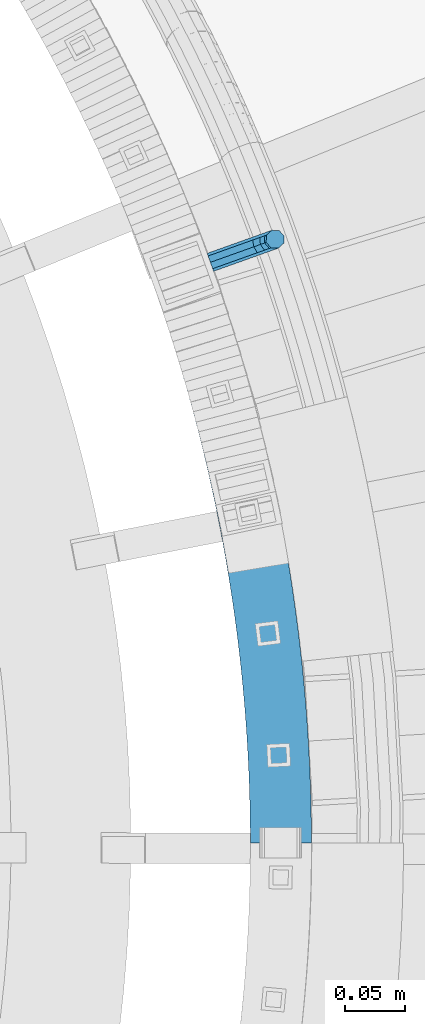
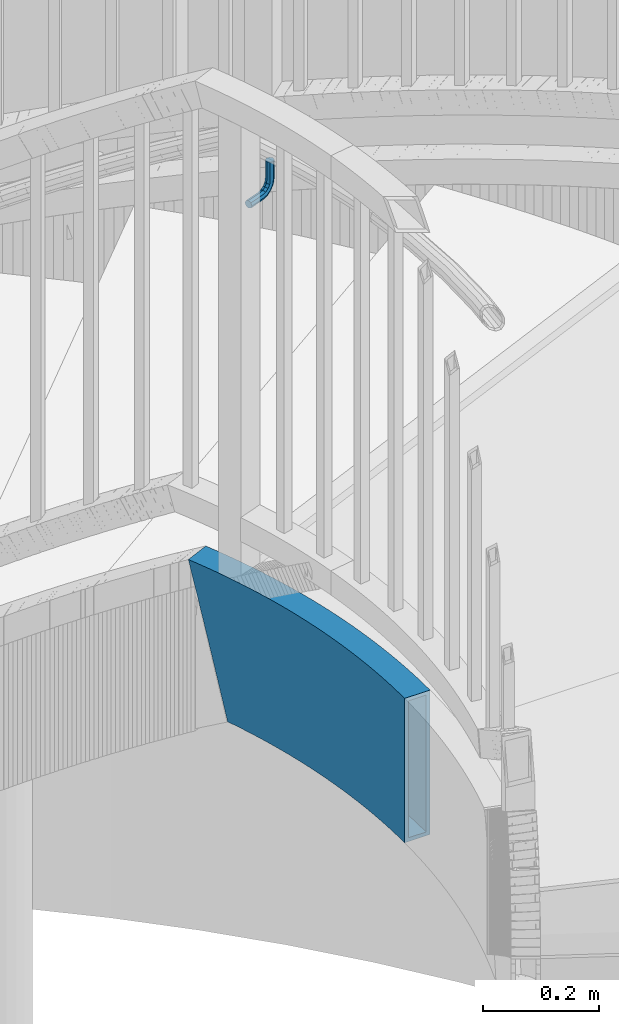
# One storey, part 497 of 975: 2 beams.
"""IFC2X3 building model written with IfcOpenShell, lengths in millimetres."""

from ifc_helpers import new_model, si_unit, frame, origin_with_axes, place, context, subcontext, project, spatial, faceted_brep, material, type_object, element, save


model = new_model("IFC2X3")

# Units and contexts
model_context = context("Model", 3, precision=1e-05, world=origin_with_axes())
body_context = subcontext(model_context, "Body", "Model", "MODEL_VIEW")
ifc_project = project(units=[si_unit("LENGTHUNIT", "METRE", prefix="MILLI"), si_unit("AREAUNIT", "SQUARE_METRE"), si_unit("VOLUMEUNIT", "CUBIC_METRE"), si_unit("MASSUNIT", "GRAM", prefix="KILO"), si_unit("TIMEUNIT", "SECOND"), si_unit("PLANEANGLEUNIT", "RADIAN"), si_unit("SOLIDANGLEUNIT", "STERADIAN"), si_unit("THERMODYNAMICTEMPERATUREUNIT", "DEGREE_CELSIUS"), si_unit("LUMINOUSINTENSITYUNIT", "LUMEN")], contexts=[model_context])

# Site, building, storey
site_placement = place(None, origin_with_axes())
site = spatial("IfcSite", under=ifc_project, at=site_placement, CompositionType="ELEMENT")
building_placement = place(site_placement, origin_with_axes())
building = spatial("IfcBuilding", under=site, at=building_placement, Name="Undefined", CompositionType="ELEMENT")
storey_placement = place(building_placement, origin_with_axes())
storey = spatial("IfcBuildingStorey", under=building, at=storey_placement, Name="Undefined", CompositionType="ELEMENT", Elevation=0.0)

# Beams
ifc_material_1 = material(Name="STEEL/A36")
beam_type_1 = type_object("IfcBeamType", PredefinedType="NOTDEFINED")
beam_1_placement = place(storey_placement, frame((36072.5932851739, 3886.01904978759, 2946.4), z_axis=(0.0, 0.0, 1.0), x_axis=(0.941586681128456, 0.336770726045925, 0.0)))
element("IfcBeam", 1, at=beam_1_placement, inside=storey, type_object=beam_type_1, material=ifc_material_1, Name="BRACKET", context=body_context, shape_type="Brep", body=[
    faceted_brep([(-4.22995071858168e-07, -7.93750000000728, 0.0), (-2.99107341561466e-07, -5.61266007567065, -5.61266007566792), (31.7501749944095, -5.61266176762365, -5.61266007566792), (31.7501748705254, -7.93750169196028, 0.0), (-1.09139364212751e-11, 1.81898940354586e-12, -7.9375), (31.7501752935095, -1.69195118360221e-06, -7.9375), (2.99089151667431e-07, 5.61266007567428, -5.61266007566792), (31.7501755926023, 5.61265838372674, -5.61266007566792), (4.22980519942939e-07, 7.93750000001091, 0.0), (31.75017571649, 7.93749830806155, 0.0), (2.99089151667431e-07, 5.61266007567428, 5.61266007566792), (31.7501755926023, 5.61265838372674, 5.61266007566792), (-1.09139364212751e-11, 1.81898940354586e-12, 7.9375), (31.7501752935095, -1.69195118360221e-06, 7.9375), (-2.99107341561466e-07, -5.61266007567065, 5.61266007566792), (31.7501749944095, -5.61266176762365, 5.61266007566792), (44.5078840739552, -2.37179847317748e-06, -5.39983394413412), (43.6182060529281, -5.61266240006626, -3.2519619216755), (41.4703339065854, -7.93750220993934, 1.93345984517509), (39.3224620080255, -5.61266217115008, 7.11888161202842), (38.4327845851803, -2.0480601961026e-06, 9.26675363448339), (39.3224626062183, 5.61265798020031, 7.11888161202842), (41.4703347525501, 7.93749779008067, 1.93345984517509), (43.6182066511174, 5.61265775128231, -3.25196192167823), (53.6794375649406, 5.61265721512609, 3.47073764613469), (55.3233473415094, -2.94815072265919e-06, 1.82682757046678), (49.7106876888392, 7.93749735095298, 7.43948764613469), (45.7419375649588, 5.61265763811389, 11.4082376461338), (44.0980271902044, -2.34995968639851e-06, 13.0521477218017), (45.7419369667659, -5.6126625132365, 11.4082376461338), (49.7106868428746, -7.93750264906703, 7.43948764613469), (53.6794369667477, -5.6126629362243, 3.47073764613469), (60.402137132729, 5.61265685687795, 13.5319685599879), (62.5500088560802, -3.3332562452415e-06, 12.6422908380455), (55.2167154897834, 7.93749705753908, 15.6798405824429), (50.0312935990514, 5.61265740953786, 17.827712604897), (47.8834212775073, -2.55168015428353e-06, 18.7173903268394), (50.0312930008622, -5.61266274181617, 17.827712604897), (55.2167146438078, -7.93750294247729, 15.6798405824429), (60.4021365345397, -5.61266329447426, 13.5319685599879), (62.7628352867068, 5.61265673108028, 25.3999996185303), (65.0876749119416, -3.46848719345871e-06, 25.3999996185303), (57.1501753349476, 7.9374969545097, 25.3999996185303), (51.5375151354019, 5.6126573292695, 25.3999996185303), (49.2126749119889, -2.62251523963641e-06, 25.3999996185303), (51.5375145372127, -5.61266282207907, 25.3999996185303), (57.1501744889792, -7.93750304551213, 25.3999996185303), (62.762834688514, -5.61266342027193, 25.3999996185303), (62.762834688514, -5.61266342027193, 63.5), (57.1501744889792, -7.93750304551213, 63.5), (65.0876749119416, -3.46848719345871e-06, 63.5), (62.7628352867068, 5.61265673108028, 63.5), (57.1501753349476, 7.9374969545097, 63.5), (51.5375151354019, 5.6126573292695, 63.5), (49.2126749119889, -2.62251523963641e-06, 63.5), (51.5375145372127, -5.61266282207907, 63.5)], [[[0, 1, 2, 3]], [[1, 4, 5, 2]], [[4, 6, 7, 5]], [[6, 8, 9, 7]], [[8, 10, 11, 9]], [[10, 12, 13, 11]], [[12, 14, 15, 13]], [[14, 0, 3, 15]], [[14, 12, 10, 8, 6, 4, 1, 0]], [[2, 5, 16, 17]], [[3, 2, 17, 18]], [[15, 3, 18, 19]], [[13, 15, 19, 20]], [[11, 13, 20, 21]], [[9, 11, 21, 22]], [[7, 9, 22, 23]], [[5, 7, 23, 16]], [[23, 24, 25, 16]], [[22, 26, 24, 23]], [[21, 27, 26, 22]], [[20, 28, 27, 21]], [[19, 29, 28, 20]], [[18, 30, 29, 19]], [[17, 31, 30, 18]], [[16, 25, 31, 17]], [[24, 32, 33, 25]], [[26, 34, 32, 24]], [[27, 35, 34, 26]], [[28, 36, 35, 27]], [[29, 37, 36, 28]], [[30, 38, 37, 29]], [[31, 39, 38, 30]], [[25, 33, 39, 31]], [[32, 40, 41, 33]], [[34, 42, 40, 32]], [[35, 43, 42, 34]], [[36, 44, 43, 35]], [[37, 45, 44, 36]], [[38, 46, 45, 37]], [[39, 47, 46, 38]], [[33, 41, 47, 39]], [[46, 47, 48, 49]], [[47, 41, 50, 48]], [[41, 40, 51, 50]], [[40, 42, 52, 51]], [[42, 43, 53, 52]], [[43, 44, 54, 53]], [[44, 45, 55, 54]], [[45, 46, 49, 55]], [[50, 51, 52, 53, 54, 55, 49, 48]]]),
])
ifc_material_2 = material()
beam_type_2 = type_object("IfcBeamType", Name="HSS12X2X5/16", PredefinedType="NOTDEFINED")
beam_2_placement = place(storey_placement, frame((36020.327060371, 3949.87201722461, 2031.99999923706), z_axis=(0.0, 0.0, 1.0), x_axis=(0.0627814950101885, -0.998027296161926, 0.0)))
element("IfcBeam", 2, at=beam_2_placement, inside=storey, type_object=beam_type_2, material=ifc_material_2, Name="STAIR", ObjectType="HSS12X2X5/16", context=body_context, shape_type="Brep", body=[
    faceted_brep([(519.591668239296, 52.6082079811895, 152.4), (519.591668239296, 52.6082079811895, -152.4), (535.331694518953, 51.8875589797681, -152.4), (535.331694518953, 51.8875589797681, 152.4), (503.84442888955, 53.1487772453038, 152.4), (503.84442888955, 53.1487772453038, -152.4), (488.092036672716, 53.5091960497084, 152.4), (488.092036672716, 53.5091960497084, -152.4), (472.336552465947, 53.6894172410102, 152.4), (472.336552465947, 53.6894172410102, -152.4), (456.580037550917, 53.6894172409666, 152.4), (456.580037550917, 53.6894172409666, -152.4), (440.824553344148, 53.5091960495702, 152.4), (440.824553344148, 53.5091960495702, -152.4), (425.072161127315, 53.1487772450782, 152.4), (425.072161127315, 53.1487772450782, -152.4), (409.324921777569, 52.6082079808766, 152.4), (409.324921777569, 52.6082079808766, -152.4), (393.584895497913, 51.8875589793606, 152.4), (393.584895497913, 51.8875589793606, -152.4), (377.854141547671, 50.9869245226655, 152.4), (377.854141547671, 50.9869245226655, -152.4), (362.134717973071, 49.9064224403191, 152.4), (362.134717973071, 49.9064224403191, -152.4), (346.428681337994, 48.6461940938243, 152.4), (346.428681337994, 48.6461940938243, -152.4), (330.738086454916, 47.2064043582141, 152.4), (330.738086454916, 47.2064043582141, -152.4), (315.064986116073, 45.5872416003986, 152.4), (315.064986116073, 45.5872416003986, -152.4), (299.411430824905, 43.7889176545941, 152.4), (299.411430824905, 43.7889176545941, -152.4), (283.779468527779, 41.8116677945654, 152.4), (283.779468527779, 41.8116677945654, -152.4), (268.171144346064, 39.6557507028847, 152.4), (268.171144346064, 39.6557507028847, -152.4), (252.588500308566, 37.3214484370328, 152.4), (252.588500308566, 37.3214484370328, -152.4), (237.033575084371, 34.8090663925468, 152.4), (237.033575084371, 34.8090663925468, -152.4), (221.508403716129, 32.1189332630238, 152.4), (221.508403716129, 32.1189332630238, -152.4), (206.015017353807, 29.2514009971928, 152.4), (206.015017353807, 29.2514009971928, -152.4), (190.555442988958, 26.2068447527636, 152.4), (190.555442988958, 26.2068447527636, -152.4), (175.131703189529, 22.9856628474154, 152.4), (175.131703189529, 22.9856628474154, -152.4), (159.745815835247, 19.5882767066869, 152.4), (159.745815835247, 19.5882767066869, -152.4), (144.399793853627, 16.015130808817, 152.4), (144.399793853627, 16.015130808817, -152.4), (129.095644956617, 12.2666926265811, 152.4), (129.095644956617, 12.2666926265811, -152.4), (113.835371377932, 8.34345256617235, 152.4), (113.835371377932, 8.34345256617235, -152.4), (98.6209696111009, 4.2459239030286, 152.4), (98.6209696111009, 4.2459239030286, -152.4), (83.4544301482701, -0.0253572853616788, 152.4), (83.4544301482701, -0.0253572853616788, -152.4), (-8.40888177997658, 23.967701333444, 152.4), (-8.40888177997658, 23.967701333444, 99.8834567786589), (-22.4314005769725, 18.9577604688093, 152.4), (7.03809672072066, 29.288134936709, 152.4), (7.03809672072066, 29.288134936709, 42.2716439026144), (22.5449192642914, 34.4315397555038, 152.4), (22.5449192642914, 34.4315397555038, -15.3247692192031), (38.1095571013357, 39.3972428808847, 152.4), (38.1095571013357, 39.3972428808847, -72.8982472784946), (53.7299739185078, 44.1845946525355, 152.4), (53.7299739185078, 44.1845946525355, -130.441257967543), (69.4041261049288, 48.7929687437645, 152.4), (69.4041261049288, 48.7929687437645, -152.4), (59.7152721478251, 45.9443385264167, -152.4), (85.1299630195485, 53.2217622434036, 152.4), (85.1299630195485, 53.2217622434036, -152.4), (100.905427259434, 57.4703957347665, 152.4), (100.905427259434, 57.4703957347665, -152.4), (116.72845492893, 61.5383133713476, 152.4), (116.72845492893, 61.5383133713476, -152.4), (132.596975909688, 65.4249829496475, 152.4), (132.596975909688, 65.4249829496475, -152.4), (148.508914131493, 69.1298959787455, 152.4), (148.508914131493, 69.1298959787455, -152.4), (164.462187843872, 72.6525677468162, 152.4), (164.462187843872, 72.6525677468162, -152.4), (180.454709888456, 75.9925373845763, 152.4), (180.454709888456, 75.9925373845763, -152.4), (196.484387972033, 79.1493679255727, 152.4), (196.484387972033, 79.1493679255727, -152.4), (212.54912494029, 82.1226463632993, 152.4), (212.54912494029, 82.1226463632993, -152.4), (228.646819052175, 84.9119837053586, 152.4), (228.646819052175, 84.9119837053586, -152.4), (244.775364254875, 87.5170150241902, 152.4), (244.775364254875, 87.5170150241902, -152.4), (260.93265045934, 89.9373995049173, 152.4), (260.93265045934, 89.9373995049173, -152.4), (277.116563816353, 92.1728204899337, 152.4), (277.116563816353, 92.1728204899337, -152.4), (293.32498699308, 94.2229855202822, 152.4), (293.32498699308, 94.2229855202822, -152.4), (309.55579945008, 96.0876263739628, 152.4), (309.55579945008, 96.0876263739628, -152.4), (325.806877718734, 97.7664991010024, 152.4), (325.806877718734, 97.7664991010024, -152.4), (342.076095679059, 99.2593840553527, 152.4), (342.076095679059, 99.2593840553527, -152.4), (358.361324837864, 100.566085923674, 152.4), (358.361324837864, 100.566085923674, -152.4), (374.660434607222, 101.686433750845, 152.4), (374.660434607222, 101.686433750845, -152.4), (390.971292583215, 102.620280962365, 152.4), (390.971292583215, 102.620280962365, -152.4), (407.291764824909, 103.367505383474, 152.4), (407.291764824909, 103.367505383474, -152.4), (423.619716133544, 103.928009255222, 152.4), (423.619716133544, 103.928009255222, -152.4), (439.953010331878, 104.301719247167, 152.4), (439.953010331878, 104.301719247167, -152.4), (456.289510543658, 104.488586467036, 152.4), (456.289510543658, 104.488586467036, -152.4), (472.627079473195, 104.488586467087, 152.4), (472.627079473195, 104.488586467087, -152.4), (488.963579684975, 104.301719247305, 152.4), (488.963579684975, 104.301719247305, -152.4), (505.296873883309, 103.928009255455, 152.4), (505.296873883309, 103.928009255455, -152.4), (521.624825191945, 103.367505383801, 152.4), (521.624825191945, 103.367505383801, -152.4), (537.945297433638, 102.620280962772, 152.4), (537.945297433638, 102.620280962772, -152.4), (553.750247250523, 101.715398562665, 152.4), (553.750247250523, 101.715398562665, -152.4), (77.1384100058035, -1.88233705932362, -152.4), (550.560948877305, 51.0156369303222, -152.4), (550.560948877305, 51.0156369303222, 152.4), (-5.04293390343355, -28.7737423929575, 152.4), (8.40888177997613, -23.9677013334585, 152.4), (23.3064805713339, -18.8364916788269, 152.4), (38.2617950215013, -13.8760146892091, 152.4), (53.2728685345896, -9.08691934117087, 152.4), (68.3377372197829, -4.46983218953392, 152.4), (8.40888177997613, -23.9677013334585, 102.020829897217), (23.3064805713339, -18.8364916788269, 46.4580106810618), (38.2617950215013, -13.8760146892091, -9.08995648102018), (53.2728685345896, -9.08691934117087, -64.6158042778327), (68.3377372197829, -4.46983218953392, -120.112268292044), (56.0124369343316, 36.5823404584662, 144.4625), (40.4788245127811, 31.8215925336917, 144.4625), (40.4788245127811, 31.8215925336917, -71.6041155596411), (56.0124369343316, 36.5823404584662, -128.827353330746), (25.0006811013554, 26.8834843735167, 144.4625), (25.0006811013554, 26.8834843735167, -14.3505797288619), (9.58003169737867, 21.7686620280292, 144.4625), (9.58003169737867, 21.7686620280292, 42.9257637117466), (-5.78110622373424, 16.4777946667382, 144.4625), (-5.78110622373424, 16.4777946667382, 100.217421328434), (-17.5950492079796, 12.2569298858725, 144.4625), (5.78110622373424, -16.4777946667527, 144.4625), (5.78110622373424, -16.4777946667527, 101.686865347442), (-5.64047836992177, -20.5584783315862, 144.4625), (20.7645455946754, -11.3170187701471, 144.4625), (20.7645455946754, -11.3170187701471, 45.8038908719291), (35.8060331844372, -6.32795930722205, 144.4625), (35.8060331844372, -6.32795930722205, -10.0641459713613), (50.9036011231442, -1.51126899397786, 144.4625), (50.9036011231442, -1.51126899397786, -65.909935996686), (66.0552742039586, 3.1324220045426, 144.4625), (66.0552742039586, 3.1324220045426, -121.726172928841), (519.909349013148, 60.5393482003492, -144.4625), (519.909349013148, 60.5393482003492, 144.4625), (535.740069974372, 59.8145467896102, 144.4625), (535.740069974372, 59.8145467896102, -144.4625), (504.071373419825, 61.0830322468901, -144.4625), (504.071373419825, 61.0830322468901, 144.4625), (488.228215268382, 61.4455277993329, -144.4625), (488.228215268382, 61.4455277993329, 144.4625), (472.381947310829, 61.6267874325858, -144.4625), (472.381947310829, 61.6267874325858, 144.4625), (456.534642706033, 61.6267874325349, -144.4625), (456.534642706033, 61.6267874325349, 144.4625), (440.688374748481, 61.4455277991947, -144.4625), (440.688374748481, 61.4455277991947, 144.4625), (424.845216597038, 61.0830322466572, -144.4625), (424.845216597038, 61.0830322466572, 144.4625), (409.007241003716, 60.5393482000363, -144.4625), (409.007241003716, 60.5393482000363, 144.4625), (393.176520042492, 59.81454678921, -144.4625), (393.176520042492, 59.81454678921, 144.4625), (377.355124838226, 58.9087228395729, -144.4625), (377.355124838226, 58.9087228395729, 144.4625), (361.545125295695, 57.821994859587, -144.4625), (361.545125295695, 57.821994859587, 144.4625), (345.748589828785, 56.5545050253131, -144.4625), (345.748589828785, 56.5545050253131, 144.4625), (329.967585089887, 55.106419161777, -144.4625), (329.967585089887, 55.106419161777, 144.4625), (314.204175699512, 53.4779267212652, -144.4625), (314.204175699512, 53.4779267212652, 144.4625), (298.460423976182, 51.6692407586088, -144.4625), (298.460423976182, 51.6692407586088, 144.4625), (282.738389666619, 49.6805979032215, -144.4625), (282.738389666619, 49.6805979032215, 144.4625), (267.040129676263, 47.5122583281991, -144.4625), (267.040129676263, 47.5122583281991, 144.4625), (251.367697800176, 45.1645057162677, -144.4625), (251.367697800176, 45.1645057162677, 144.4625), (235.72314445434, 42.6376472226766, -144.4625), (235.72314445434, 42.6376472226766, 144.4625), (220.108516407404, 39.9320134349473, -144.4625), (220.108516407404, 39.9320134349473, 144.4625), (204.525856512905, 37.0479583297492, -144.4625), (204.525856512905, 37.0479583297492, 144.4625), (188.977203442005, 33.9858592264718, -144.4625), (188.977203442005, 33.9858592264718, 144.4625), (173.46459141677, 30.7461167379442, -144.4625), (173.46459141677, 30.7461167379442, 144.4625), (157.990049944035, 27.3291547179397, -144.4625), (157.990049944035, 27.3291547179397, 144.4625), (142.555603549887, 23.7354202058195, -144.4625), (142.555603549887, 23.7354202058195, 144.4625), (127.163271514791, 19.9653833679477, -144.4625), (127.163271514791, 19.9653833679477, 144.4625), (111.815067609416, 16.0195374362665, -144.4625), (111.815067609416, 16.0195374362665, 144.4625), (96.5129998311709, 11.8983986437088, -144.4625), (96.5129998311709, 11.8983986437088, 144.4625), (81.2590701414974, 7.60250615668338, -144.4625), (81.2590701414974, 7.60250615668338, 144.4625), (72.2525189258572, 4.95448049125844, -144.4625), (60.2741116484972, 37.835319956459, -144.4625), (71.599486111701, 41.1651053017122, -144.4625), (71.599486111701, 41.1651053017122, 144.4625), (87.237932799479, 45.5692875027235, -144.4625), (87.237932799479, 45.5692875027235, 144.4625), (102.925731027949, 49.7943108646723, -144.4625), (102.925731027949, 49.7943108646723, 144.4625), (118.660828370756, 53.839622629981, -144.4625), (118.660828370756, 53.839622629981, 144.4625), (134.441166213429, 57.7046935526378, -144.4625), (134.441166213429, 57.7046935526378, 144.4625), (150.264680022705, 61.3890179674854, -144.4625), (150.264680022705, 61.3890179674854, 144.4625), (166.129299616631, 64.8921138562873, -144.4625), (166.129299616631, 64.8921138562873, 144.4625), (182.032949435409, 68.2135229108535, -144.4625), (182.032949435409, 68.2135229108535, 144.4625), (197.973548812935, 71.3528105930091, -144.4625), (197.973548812935, 71.3528105930091, 144.4625), (213.949012249014, 74.3095661913903, -144.4625), (213.949012249014, 74.3095661913903, 144.4625), (229.957249682206, 77.0834028752288, -144.4625), (229.957249682206, 77.0834028752288, 144.4625), (245.996166763263, 79.6739577449407, -144.4625), (245.996166763263, 79.6739577449407, 144.4625), (262.063665129141, 82.0808918796029, -144.4625), (262.063665129141, 82.0808918796029, 144.4625), (278.157642677513, 84.3038903812776, -144.4625), (278.157642677513, 84.3038903812776, 144.4625), (294.275993841803, 86.3426624162676, -144.4625), (294.275993841803, 86.3426624162676, 144.4625), (310.416609866641, 88.1969412530962, -144.4625), (310.416609866641, 88.1969412530962, 144.4625), (326.577379083762, 89.8664842974395, -144.4625), (326.577379083762, 89.8664842974395, 144.4625), (342.756187188267, 91.3510731238639, -144.4625), (342.756187188267, 91.3510731238639, 144.4625), (358.95091751524, 92.650513504399, -144.4625), (358.95091751524, 92.650513504399, 144.4625), (375.159451316668, 93.7646354339449, -144.4625), (375.159451316668, 93.7646354339449, 144.4625), (391.379668038636, 94.6932931525153, -144.4625), (391.379668038636, 94.6932931525153, 144.4625), (407.609445598762, 95.4363651643289, -144.4625), (407.609445598762, 95.4363651643289, 144.4625), (423.846660663821, 95.9937542536354, -144.4625), (423.846660663821, 95.9937542536354, 144.4625), (440.089188927544, 96.3653874975425, -144.4625), (440.089188927544, 96.3653874975425, 144.4625), (456.334905388542, 96.5512162754603, -144.4625), (456.334905388542, 96.5512162754603, 144.4625), (472.581684628312, 96.551216275504, -144.4625), (472.581684628312, 96.551216275504, 144.4625), (488.82740108931, 96.3653874976808, -144.4625), (488.82740108931, 96.3653874976808, 144.4625), (505.069929353034, 95.9937542538755, -144.4625), (505.069929353034, 95.9937542538755, 144.4625), (521.307144418093, 95.436365164649, -144.4625), (521.307144418093, 95.436365164649, 144.4625), (537.536921978219, 94.6932931529373, -144.4625), (537.536921978219, 94.6932931529373, 144.4625), (553.251919379708, 93.793560807615, 144.4625), (551.05927674812, 58.9374746853719, 144.4625), (551.05927674812, 58.9374746853719, -144.4625), (553.251919379708, 93.793560807615, -144.4625)], [[[0, 1, 2, 3]], [[4, 5, 1, 0]], [[6, 7, 5, 4]], [[8, 9, 7, 6]], [[10, 11, 9, 8]], [[12, 13, 11, 10]], [[14, 15, 13, 12]], [[16, 17, 15, 14]], [[18, 19, 17, 16]], [[20, 21, 19, 18]], [[22, 23, 21, 20]], [[24, 25, 23, 22]], [[26, 27, 25, 24]], [[28, 29, 27, 26]], [[30, 31, 29, 28]], [[32, 33, 31, 30]], [[34, 35, 33, 32]], [[36, 37, 35, 34]], [[38, 39, 37, 36]], [[40, 41, 39, 38]], [[42, 43, 41, 40]], [[44, 45, 43, 42]], [[46, 47, 45, 44]], [[48, 49, 47, 46]], [[50, 51, 49, 48]], [[52, 53, 51, 50]], [[54, 55, 53, 52]], [[56, 57, 55, 54]], [[58, 59, 57, 56]], [[60, 61, 62]], [[60, 63, 64, 61]], [[63, 65, 66, 64]], [[65, 67, 68, 66]], [[67, 69, 70, 68]], [[69, 71, 72, 73, 70]], [[72, 71, 74, 75]], [[75, 74, 76, 77]], [[77, 76, 78, 79]], [[79, 78, 80, 81]], [[81, 80, 82, 83]], [[83, 82, 84, 85]], [[85, 84, 86, 87]], [[87, 86, 88, 89]], [[89, 88, 90, 91]], [[91, 90, 92, 93]], [[93, 92, 94, 95]], [[95, 94, 96, 97]], [[97, 96, 98, 99]], [[99, 98, 100, 101]], [[101, 100, 102, 103]], [[103, 102, 104, 105]], [[105, 104, 106, 107]], [[107, 106, 108, 109]], [[109, 108, 110, 111]], [[111, 110, 112, 113]], [[113, 112, 114, 115]], [[115, 114, 116, 117]], [[117, 116, 118, 119]], [[119, 118, 120, 121]], [[121, 120, 122, 123]], [[123, 122, 124, 125]], [[125, 124, 126, 127]], [[127, 126, 128, 129]], [[129, 128, 130, 131]], [[131, 130, 132, 133]], [[2, 1, 5, 7, 9, 11, 13, 15, 17, 19, 21, 23, 25, 27, 29, 31, 33, 35, 37, 39, 41, 43, 45, 47, 49, 51, 53, 55, 57, 59, 134, 73, 72, 75, 77, 79, 81, 83, 85, 87, 89, 91, 93, 95, 97, 99, 101, 103, 105, 107, 109, 111, 113, 115, 117, 119, 121, 123, 125, 127, 129, 131, 133, 135]], [[3, 2, 135, 136]], [[130, 128, 126, 124, 122, 120, 118, 116, 114, 112, 110, 108, 106, 104, 102, 100, 98, 96, 94, 92, 90, 88, 86, 84, 82, 80, 78, 76, 74, 71, 69, 67, 65, 63, 60, 62, 137, 138, 139, 140, 141, 142, 58, 56, 54, 52, 50, 48, 46, 44, 42, 40, 38, 36, 34, 32, 30, 28, 26, 24, 22, 20, 18, 16, 14, 12, 10, 8, 6, 4, 0, 3, 136, 132]], [[138, 137, 143]], [[139, 138, 143, 144]], [[140, 139, 144, 145]], [[141, 140, 145, 146]], [[142, 141, 146, 147]], [[59, 58, 142, 147, 134]], [[148, 149, 150, 151]], [[149, 152, 153, 150]], [[152, 154, 155, 153]], [[154, 156, 157, 155]], [[156, 158, 157]], [[159, 160, 161]], [[159, 162, 163, 160]], [[162, 164, 165, 163]], [[164, 166, 167, 165]], [[166, 168, 169, 167]], [[170, 171, 172, 173]], [[174, 175, 171, 170]], [[176, 177, 175, 174]], [[178, 179, 177, 176]], [[180, 181, 179, 178]], [[182, 183, 181, 180]], [[184, 185, 183, 182]], [[186, 187, 185, 184]], [[188, 189, 187, 186]], [[190, 191, 189, 188]], [[192, 193, 191, 190]], [[194, 195, 193, 192]], [[196, 197, 195, 194]], [[198, 199, 197, 196]], [[200, 201, 199, 198]], [[202, 203, 201, 200]], [[204, 205, 203, 202]], [[206, 207, 205, 204]], [[208, 209, 207, 206]], [[210, 211, 209, 208]], [[212, 213, 211, 210]], [[214, 215, 213, 212]], [[216, 217, 215, 214]], [[218, 219, 217, 216]], [[220, 221, 219, 218]], [[222, 223, 221, 220]], [[224, 225, 223, 222]], [[226, 227, 225, 224]], [[228, 229, 227, 226]], [[168, 229, 228, 230, 169]], [[146, 145, 144, 143, 137, 62, 61, 64, 66, 68, 70, 73, 134, 147], [151, 150, 153, 155, 157, 158, 161, 160, 163, 165, 167, 169, 230, 231]], [[232, 233, 148, 151, 231]], [[233, 232, 234, 235]], [[235, 234, 236, 237]], [[237, 236, 238, 239]], [[239, 238, 240, 241]], [[241, 240, 242, 243]], [[243, 242, 244, 245]], [[245, 244, 246, 247]], [[247, 246, 248, 249]], [[249, 248, 250, 251]], [[251, 250, 252, 253]], [[253, 252, 254, 255]], [[255, 254, 256, 257]], [[257, 256, 258, 259]], [[259, 258, 260, 261]], [[261, 260, 262, 263]], [[263, 262, 264, 265]], [[265, 264, 266, 267]], [[267, 266, 268, 269]], [[269, 268, 270, 271]], [[271, 270, 272, 273]], [[273, 272, 274, 275]], [[275, 274, 276, 277]], [[277, 276, 278, 279]], [[279, 278, 280, 281]], [[281, 280, 282, 283]], [[283, 282, 284, 285]], [[285, 284, 286, 287]], [[287, 286, 288, 289]], [[289, 288, 290, 291]], [[172, 171, 175, 177, 179, 181, 183, 185, 187, 189, 191, 193, 195, 197, 199, 201, 203, 205, 207, 209, 211, 213, 215, 217, 219, 221, 223, 225, 227, 229, 168, 166, 164, 162, 159, 161, 158, 156, 154, 152, 149, 148, 233, 235, 237, 239, 241, 243, 245, 247, 249, 251, 253, 255, 257, 259, 261, 263, 265, 267, 269, 271, 273, 275, 277, 279, 281, 283, 285, 287, 289, 291, 292, 293]], [[173, 172, 293, 294]], [[290, 288, 286, 284, 282, 280, 278, 276, 274, 272, 270, 268, 266, 264, 262, 260, 258, 256, 254, 252, 250, 248, 246, 244, 242, 240, 238, 236, 234, 232, 231, 230, 228, 226, 224, 222, 220, 218, 216, 214, 212, 210, 208, 206, 204, 202, 200, 198, 196, 194, 192, 190, 188, 186, 184, 182, 180, 178, 176, 174, 170, 173, 294, 295]], [[291, 290, 295, 292]], [[135, 133, 132, 136], [294, 293, 292, 295]]]),
])

save(model, "model.ifc")
